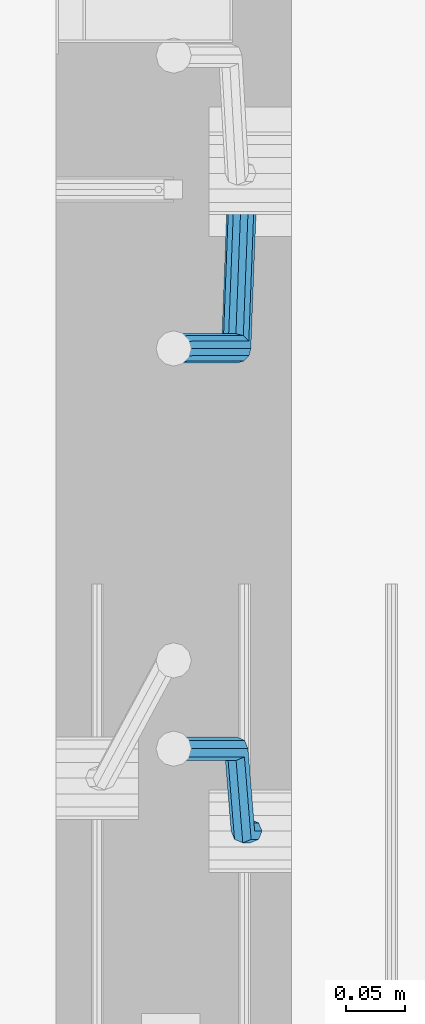
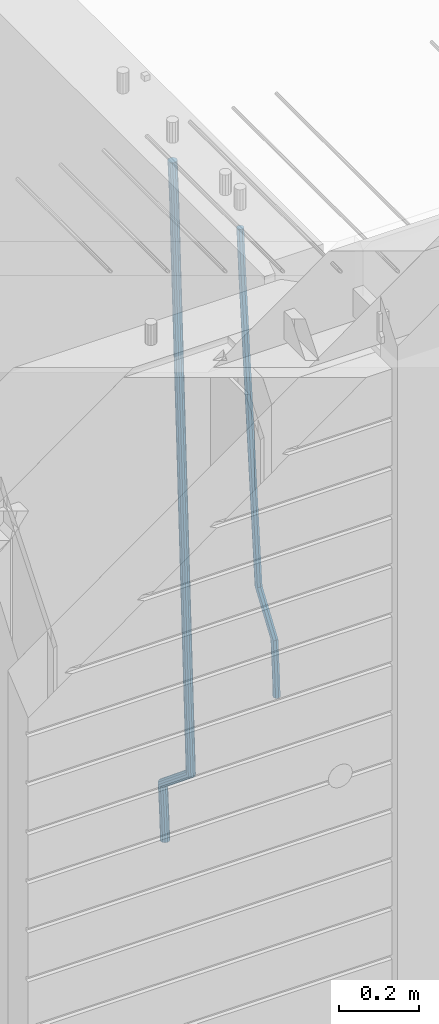
# One storey, part 104 of 341: 2 beams, 1 element without a shape of its own.
"""IFC2X3 building model written with IfcOpenShell, lengths in millimetres."""

from ifc_helpers import new_model, si_unit, frame, origin_with_axes, place, context, subcontext, project, spatial, faceted_brep, material, type_object, element, aggregate, save


model = new_model("IFC2X3")

# Units and contexts
model_context = context("Model", 3, precision=1e-05, world=origin_with_axes())
body_context = subcontext(model_context, "Body", "Model", "MODEL_VIEW")
ifc_project = project(units=[si_unit("LENGTHUNIT", "METRE", prefix="MILLI"), si_unit("AREAUNIT", "SQUARE_METRE"), si_unit("VOLUMEUNIT", "CUBIC_METRE"), si_unit("MASSUNIT", "GRAM", prefix="KILO"), si_unit("TIMEUNIT", "SECOND"), si_unit("PLANEANGLEUNIT", "RADIAN"), si_unit("SOLIDANGLEUNIT", "STERADIAN"), si_unit("THERMODYNAMICTEMPERATUREUNIT", "DEGREE_CELSIUS"), si_unit("LUMINOUSINTENSITYUNIT", "LUMEN")], contexts=[model_context])

# Site, building, storey
site_placement = place(None, origin_with_axes())
site = spatial("IfcSite", under=ifc_project, at=site_placement, CompositionType="ELEMENT")
building_placement = place(site_placement, origin_with_axes())
building = spatial("IfcBuilding", under=site, at=building_placement, CompositionType="ELEMENT")
storey_placement = place(building_placement, origin_with_axes())
storey = spatial("IfcBuildingStorey", under=building, at=storey_placement, Name="5", CompositionType="ELEMENT", Elevation=0.0)

# Assembly, beams
assembly_placement = place(storey_placement, origin_with_axes())
assembly = element("IfcElementAssembly", 1, at=assembly_placement, inside=storey, AssemblyPlace="NOTDEFINED", PredefinedType="REINFORCEMENT_UNIT")
ifc_material = material()
beam_type_1 = type_object("IfcBeamType", Name="D20", PredefinedType="NOTDEFINED")
beam_1_placement = place(assembly_placement, frame((28675.0000022791, 8255.00000000393, 94990.0), z_axis=(-0.999642804636942, -0.000205726999925762, -0.0267249099902983), x_axis=(-0.0267249099948371, 4.30000201934385e-08, 0.999642825806181)))
beam_1 = element("IfcBeam", 2, at=beam_1_placement, type_object=beam_type_1, material=ifc_material, Name="JM20", ObjectType="D20", context=body_context, shape_type="Brep", body=[
    faceted_brep([(0.0, -10.0, 0.0), (-4.19531716033816e-08, -7.07106781186667, -7.07106781187031), (60.4266690400545, -7.0710677960451, -7.07106780570757), (60.4266690441291, -9.99999998418934, 6.15546014159918e-09), (0.0, 0.0, -10.0), (60.426669036824, 1.58106558956206e-08, -9.99999999384454), (4.196772351861e-08, 7.07106781186303, -7.07106781186667), (60.4266690363438, 7.07106782768096, -7.07106780570757), (0.0, 10.0, 0.0), (60.4266690388904, 10.0000000158179, 6.15182216279209e-09), (4.196772351861e-08, 7.07106781185939, 7.07106781185939), (60.4266690429649, 7.07106782768096, 7.07106781802577), (0.0, 0.0, 10.0), (60.4266690461809, 1.58179318532348e-08, 10.0000000061555), (-4.19531716033816e-08, -7.07106781187031, 7.07106781185939), (60.4266690466611, -7.07106779605238, 7.07106781802213), (61.0378400410118, -7.07106779588503, -7.07106780564936), (60.991799419251, -9.99999998403655, 6.21366780251265e-09), (61.0569027789461, 1.5985278878361e-08, -9.99999999378269), (61.0378209396877, 7.07106782784831, -7.07106780564936), (60.9917724058905, 10.0000000159635, 6.21366780251265e-09), (60.9457317841297, 7.07106782781193, 7.0710678180767), (60.9266690461809, 1.59488990902901e-08, 10.0000000062028), (60.9457508854539, -7.07106779591413, 7.0710678180767), (61.6489592143771, -7.07106614513759, -7.06310863441468), (61.5568818710308, -9.9999984576425, 0.00735959856683621), (61.6870830769039, 1.71821739058942e-06, -9.99179257185824), (61.6489210170112, 7.07106947854481, -7.06310888312146), (61.556827851804, 10.0000015422847, 0.00735924683976918), (61.4647505084577, 7.07106922979438, 7.07782747982128), (61.4266266459163, 1.36643211590126e-06, 10.0065114172685), (61.464788705809, -7.07106639389531, 7.07782772852806), (173.929884088837, -7.07076285404219, -5.60077011527756), (173.837806745476, -9.99969516654164, 1.46969811770396), (173.968007951422, 0.000305009316434735, -8.52945405272476), (173.929845891558, 7.07137276964022, -5.6007703639807), (173.837752726366, 10.0003048333874, 1.46969776598417), (173.745675383005, 7.07137252088796, 8.54016599896204), (173.70755152042, 0.000304657529341057, 11.4688499364056), (173.745713580298, -7.07076310279444, 8.54016624766882), (178.967651291154, -7.07074924610424, -5.53515860522748), (179.629472357934, -9.99967952218321, 1.54512834527122), (177.143594814726, 0.000313587164782803, -8.48809544264077), (175.225810474018, 7.07137627027805, -5.58389181644088), (174.337710326101, 10.0003061838652, 1.47620917704262), (174.999531392881, 7.07137590778439, 8.5564961275486), (176.823587869323, 0.000313074517180212, 11.5094329649655), (178.741372210017, -7.07074960859609, 8.60522933875836), (183.345669120055, -4.57893716864601, -5.45009559540631), (184.66265755528, -7.13496947462954, 1.64292097623184), (179.903304691441, 1.57104232098936, -8.43447546265816), (176.352054665098, 7.71239441757098, -5.56200937456015), (174.772193143071, 10.2475983542226, 1.48465099193709), (176.089181578311, 7.69156604824093, 8.57766756357887), (179.531546006911, 1.54158655860192, 11.5620474308307), (183.082796033268, -4.59976553797787, 8.68958134273271), (300.866238429953, 62.309592161384, -3.16672130776351), (302.183226865163, 59.7535598554005, 3.92629526388191), (297.423874001339, 68.4595716510194, -6.15110117501899), (293.872623974981, 74.6009237475992, -3.27863508691371), (292.292762452984, 77.1361276842526, 3.7680252795908), (293.609750888194, 74.5800953782691, 10.8610418512253), (297.052115316808, 68.4301158886319, 13.8454217184808), (300.603365343151, 62.2887637920539, 10.9729556303828), (301.984297885341, 62.9459518481417, -3.14499789178808), (302.617709682163, 60.0008520257597, 3.93473707877274), (300.171977137725, 70.023694240961, -6.09770670902071), (298.242380353928, 77.0880337014878, -3.19373259352506), (297.325839159952, 80.0007759829532, 3.86581580262282), (297.959250956774, 77.0556761605694, 10.9455507731909), (299.771571704376, 69.9779337677501, 13.8982595904236), (301.701168488187, 62.9135943072251, 10.9942854749243), (303.270651347979, 62.9459576083173, -3.11711828318948), (303.117592289826, 60.0008542641881, 3.94557121718026), (303.333733847743, 70.0237083990232, -6.02918080060772), (303.269886916285, 77.0880562142083, -3.08476960685584), (303.116511220142, 80.0008019130601, 3.99131915397084), (302.963452161959, 77.0556985689309, 11.0540086543406), (302.900369662209, 69.9779477782249, 13.9660711717588), (302.964216593668, 62.9135999630416, 11.0216599780069), (1294.7217320068, 62.9503972368293, 18.3709632433638), (1294.56867294862, 60.005293892702, 25.4336527437299), (1294.78481450655, 70.0281480275353, 15.4589007259456), (1294.72096757509, 77.0924958427204, 18.4033119196974), (1294.56759187893, 80.0052415415721, 25.4794006805241), (1294.41453282078, 77.0601381974448, 32.5420901808939), (1294.35145032103, 69.9823874067388, 35.4541526983121), (1294.41529725248, 62.9180395915519, 32.5097415045602), (1295.22161461448, 62.9503994752577, 18.3817973817677), (1295.07888017438, 60.0052961773617, 25.4447106513508), (1295.31867057628, 70.028150418093, 15.4704711836021), (1295.31319399366, 77.0924984946578, 18.4161474592547), (1295.20839297447, 80.0052444110206, 25.4932889968004), (1295.06565853437, 77.0601411131283, 32.5562022663908), (1294.96860257258, 69.9823901702894, 35.4675284645564), (1294.97407915516, 62.9180420937282, 32.5218521889037), (1295.72152784184, 62.94388042639, 18.3884507330331), (1295.58911865226, 59.9986424835042, 25.4515014215031), (1295.85255934671, 70.0211883158863, 15.477576715788), (1295.90545668837, 77.0847751754136, 18.4240298907134), (1295.84923332153, 79.9968876216644, 25.5018179488325), (1295.71682413192, 77.0516496787768, 32.5648686373061), (1295.58579262707, 69.9743417892805, 35.4757426545511), (1295.53289528542, 62.9107549297532, 32.5292894796257), (1317.55234549895, 62.6591986870044, 18.6789973526284), (1317.41993630935, 59.7139607441186, 25.742048041102), (1317.68337700378, 69.7365065765007, 15.7681233353796), (1317.73627434546, 76.8000934360261, 18.7145765103051), (1317.68005097858, 79.7122058822752, 25.7923645684241), (1317.54764178899, 76.7669679393894, 32.8554152568977), (1317.41661028414, 69.6896600498949, 35.7662892741391), (1317.36371294248, 62.6260731903676, 32.8198360992174), (1318.18764454535, 62.6509141582064, 18.6874525554158), (1318.08001896468, 59.7053530281173, 25.7508330892488), (1318.26149780396, 69.7289676726632, 15.7758175521922), (1318.25831650323, 76.7932858179247, 18.7215243757819), (1318.17996420598, 79.7056868334112, 25.7990179196931), (1318.07233862529, 76.7601257033202, 32.8623984535188), (1317.9984853667, 69.6820721888635, 35.7740334567425), (1318.00166666745, 62.617754043602, 32.82832663316), (1318.82299738188, 62.6527874709518, 18.695714940186), (1318.74015733854, 59.7073214972279, 25.7594258266035), (1318.83966783619, 69.7306617061313, 15.783316930032), (1318.78040337538, 76.7948214685675, 18.7282750514532), (1318.67992031686, 79.7071777761994, 25.8054727775416), (1318.59708027351, 76.7617118024755, 32.8691836639591), (1318.58040981922, 69.683837567296, 35.7815816741204), (1318.63967428004, 62.6196778048579, 32.8366235526955), (1418.84378630333, 62.9510503382135, 19.9930854252816), (1418.76094625996, 60.0055843644896, 27.0567963116991), (1418.86045675761, 70.0289245733893, 17.080687415124), (1418.8011922968, 77.0930843358292, 20.0256455365488), (1418.70070923828, 80.0054406434592, 27.1028432626408), (1418.61786919495, 77.0599746697353, 34.1665541490511), (1418.60119874065, 69.9821004345595, 37.078952159216), (1418.66046320145, 62.9179406721196, 34.1339940377911)], [[[0, 1, 2, 3]], [[1, 4, 5, 2]], [[4, 6, 7, 5]], [[6, 8, 9, 7]], [[8, 10, 11, 9]], [[10, 12, 13, 11]], [[12, 14, 15, 13]], [[14, 0, 3, 15]], [[14, 12, 10, 8, 6, 4, 1, 0]], [[3, 2, 16, 17]], [[2, 5, 18, 16]], [[5, 7, 19, 18]], [[7, 9, 20, 19]], [[9, 11, 21, 20]], [[11, 13, 22, 21]], [[13, 15, 23, 22]], [[15, 3, 17, 23]], [[17, 16, 24, 25]], [[16, 18, 26, 24]], [[18, 19, 27, 26]], [[19, 20, 28, 27]], [[20, 21, 29, 28]], [[21, 22, 30, 29]], [[22, 23, 31, 30]], [[23, 17, 25, 31]], [[25, 24, 32, 33]], [[24, 26, 34, 32]], [[26, 27, 35, 34]], [[27, 28, 36, 35]], [[28, 29, 37, 36]], [[29, 30, 38, 37]], [[30, 31, 39, 38]], [[31, 25, 33, 39]], [[33, 32, 40, 41]], [[32, 34, 42, 40]], [[34, 35, 43, 42]], [[35, 36, 44, 43]], [[36, 37, 45, 44]], [[37, 38, 46, 45]], [[38, 39, 47, 46]], [[39, 33, 41, 47]], [[41, 40, 48, 49]], [[40, 42, 50, 48]], [[42, 43, 51, 50]], [[43, 44, 52, 51]], [[44, 45, 53, 52]], [[45, 46, 54, 53]], [[46, 47, 55, 54]], [[47, 41, 49, 55]], [[49, 48, 56, 57]], [[48, 50, 58, 56]], [[50, 51, 59, 58]], [[51, 52, 60, 59]], [[52, 53, 61, 60]], [[53, 54, 62, 61]], [[54, 55, 63, 62]], [[55, 49, 57, 63]], [[57, 56, 64, 65]], [[56, 58, 66, 64]], [[58, 59, 67, 66]], [[59, 60, 68, 67]], [[60, 61, 69, 68]], [[61, 62, 70, 69]], [[62, 63, 71, 70]], [[63, 57, 65, 71]], [[65, 64, 72, 73]], [[64, 66, 74, 72]], [[66, 67, 75, 74]], [[67, 68, 76, 75]], [[68, 69, 77, 76]], [[69, 70, 78, 77]], [[70, 71, 79, 78]], [[71, 65, 73, 79]], [[73, 72, 80, 81]], [[72, 74, 82, 80]], [[74, 75, 83, 82]], [[75, 76, 84, 83]], [[76, 77, 85, 84]], [[77, 78, 86, 85]], [[78, 79, 87, 86]], [[79, 73, 81, 87]], [[81, 80, 88, 89]], [[80, 82, 90, 88]], [[82, 83, 91, 90]], [[83, 84, 92, 91]], [[84, 85, 93, 92]], [[85, 86, 94, 93]], [[86, 87, 95, 94]], [[87, 81, 89, 95]], [[89, 88, 96, 97]], [[88, 90, 98, 96]], [[90, 91, 99, 98]], [[91, 92, 100, 99]], [[92, 93, 101, 100]], [[93, 94, 102, 101]], [[94, 95, 103, 102]], [[95, 89, 97, 103]], [[97, 96, 104, 105]], [[96, 98, 106, 104]], [[98, 99, 107, 106]], [[99, 100, 108, 107]], [[100, 101, 109, 108]], [[101, 102, 110, 109]], [[102, 103, 111, 110]], [[103, 97, 105, 111]], [[105, 104, 112, 113]], [[104, 106, 114, 112]], [[106, 107, 115, 114]], [[107, 108, 116, 115]], [[108, 109, 117, 116]], [[109, 110, 118, 117]], [[110, 111, 119, 118]], [[111, 105, 113, 119]], [[113, 112, 120, 121]], [[112, 114, 122, 120]], [[114, 115, 123, 122]], [[115, 116, 124, 123]], [[116, 117, 125, 124]], [[117, 118, 126, 125]], [[118, 119, 127, 126]], [[119, 113, 121, 127]], [[121, 120, 128, 129]], [[120, 122, 130, 128]], [[122, 123, 131, 130]], [[123, 124, 132, 131]], [[124, 125, 133, 132]], [[125, 126, 134, 133]], [[126, 127, 135, 134]], [[127, 121, 129, 135]], [[130, 131, 132, 133, 134, 135, 129, 128]]]),
])
beam_type_2 = type_object("IfcBeamType", Name="D25", PredefinedType="NOTDEFINED")
beam_2_placement = place(assembly_placement, frame((28675.0000022791, 8815.00000000393, 94210.0), z_axis=(-0.999642804636942, -0.000205726999925762, -0.0267249099902983), x_axis=(-0.0267249099948371, 4.30000201934385e-08, 0.999642825806181)))
beam_2 = element("IfcBeam", 3, at=beam_2_placement, type_object=beam_type_2, material=ifc_material, Name="JM25", ObjectType="D25", context=body_context, shape_type="Brep", body=[
    faceted_brep([(-7.41420080885291e-08, -12.5, -3.63797880709171e-12), (-6.42030499875546e-08, -10.8253175473074, -6.25000000000364), (60.4103898235917, -10.8253175318459, -6.2499999938409), (60.4103898269532, -12.4999999845422, 6.16273609921336e-09), (-3.70782800018787e-08, -6.25000000000364, -10.8253175473074), (60.4103898202884, -6.24999998454587, -10.8253175411446), (-1.45519152283669e-11, -3.63797880709171e-12, -12.5), (60.4103898179019, 1.54577719513327e-08, -12.4999999938373), (3.70637280866504e-08, 6.25, -10.8253175473074), (60.410389817087, 6.25000001545777, -10.825317541141), (6.42030499875546e-08, 10.8253175473001, -6.25000000000364), (60.410389818062, 10.8253175627578, -6.24999999383726), (7.41420080885291e-08, 12.4999999999927, 0.0), (60.4103898205503, 12.5000000154541, 6.16273609921336e-09), (6.42176019027829e-08, 10.8253175473001, 6.24999999999636), (60.4103898238973, 10.8253175627651, 6.2500000061591), (3.70928319171071e-08, 6.24999999999636, 10.8253175473037), (60.4103898272151, 6.25000001546141, 10.8253175534664), (1.45519152283669e-11, -3.63797880709171e-12, 12.4999999999964), (60.4103898296162, 1.54541339725256e-08, 12.5000000061591), (-3.7049176171422e-08, -6.25000000000364, 10.8253175473001), (60.4103898304165, -6.24999998454587, 10.8253175534701), (-6.41884980723262e-08, -10.8253175473074, 6.25), (60.4103898294561, -10.8253175318459, 6.25000000616637), (61.0324985728803, -10.8253175316895, -6.24999999377542), (60.991802792938, -12.4999999843931, 6.22458173893392e-09), (61.0622854283865, -6.24999998437852, -10.8253175410755), (61.0731819955545, 1.5628756955266e-08, -12.4999999937718), (61.0622685480339, 6.25000001562512, -10.8253175410791), (61.032469335245, 10.8253175629216, -6.24999999377178), (60.9917690322181, 12.5000000156033, 6.22458173893392e-09), (60.9510732522613, 10.8253175629034, 6.25000000621731), (60.9212863967696, 6.25000001558874, 10.8253175535247), (60.9103898296162, 1.55814632307738e-08, 12.5000000062137), (60.9213032771368, -6.24999998441126, 10.8253175535174), (60.9511024898966, -10.8253175317113, 6.25000000621731), (61.6545545670233, -10.8253158516927, -6.24189838219536), (61.573166454793, -12.499998414296, 0.00757164385504439), (61.7141257553885, -6.24999822394238, -10.8168280205282), (61.7359179680789, 1.80548886419274e-06, -12.491368569139), (61.7140919992817, 6.25000177601396, -10.8168282403167), (61.6544960997562, 10.8253192428383, -6.2418987628771), (61.5730989426083, 12.5000015856094, 0.0075712042817031), (61.4917108303925, 10.8253190230062, 6.25704123032847), (61.4321396420273, 6.25000139525582, 10.8319708686649), (61.4103474293224, 1.36582457344048e-06, 12.5065114172721), (61.4321733981196, -6.24999860470052, 10.8319710884571), (61.4917692976451, -10.8253160715249, 6.25704161101385), (170.650707434237, -10.8250214850323, -4.82234049238832), (170.569319321992, -12.4997040476355, 1.42712953365844), (170.710278622631, -6.24970385728193, -9.39727013072479), (170.732070835351, 0.000296172149319318, -11.071810679332), (170.710244866626, 6.2502961426726, -9.39727035051328), (170.650648967101, 10.8256136094988, -4.8223408730737), (170.569251809982, 12.5002959522735, 1.42712909408874), (170.487863697752, 10.8256133896703, 7.67659912013187), (170.428292509343, 6.2502957619181, 12.2515287584683), (170.406500296609, 0.000295732492304523, 13.9260693070792), (170.428326265363, -6.24970423803461, 12.2515289782568), (170.487922164859, -10.825021704859, 7.67659950081725), (171.95945989441, -10.8250179504703, -4.80529539646886), (171.069276921742, -12.4997026973942, 1.43364094472054), (174.195854831123, -6.24969444374983, -9.35187424218384), (177.179221514642, 0.00031358403248305, -10.9878434623934), (180.110169251391, 6.25032152914355, -9.2748464256947), (182.203352962257, 10.8256448100037, -4.67187930471846), (182.897905762278, 12.5003292483925, 1.58769657769517), (182.007722789611, 10.8256445014722, 7.82663291887729), (179.771327852883, 6.25032099474811, 12.3732117645959), (176.787961169364, 0.000312966967612738, 14.0091809848018), (173.857013432615, -6.24969497814527, 12.2961839481068), (171.763829721749, -10.8250182590036, 7.69321682713053), (172.789272050257, -11.8370779460765, -4.78886711087034), (171.386274143355, -12.8863205656235, 1.43991672756601), (176.405878190024, -8.94509510172611, -9.30812109317048), (181.267025868161, -4.98527650023061, -10.9069147643713), (186.070174490029, -1.01865233804529, -9.15685265142747), (189.528324261279, 1.89192364390146, -4.52686248419923), (190.714866743365, 2.96656496173455, 1.74245361104113), (189.311868836463, 1.91732234219126, 7.97123744947385), (185.695262696681, -0.974660502160987, 12.4904914317667), (180.834115018544, -4.93447910365467, 14.0892851029712), (176.030966396691, -8.90110326583999, 12.339222990031), (172.572816625441, -11.8116792477867, 7.70923282279909), (287.643682825365, -151.916436441259, -2.51502591843382), (286.240684918463, -152.965679060806, 3.71375791999526), (291.260288965132, -149.024453596909, -7.03427990073396), (296.121436643283, -145.064634995419, -8.63307357193844), (300.924585265137, -141.098010833231, -6.88301145899459), (304.382735036386, -138.187434851283, -2.25302129176634), (305.569277518473, -137.11279353345, 4.01629480347401), (304.166279611571, -138.162036152991, 10.2450786419104), (300.549673471804, -141.054018997345, 14.7643326242032), (295.688525793681, -145.013837598837, 16.3631262954077), (290.885377171784, -148.980461761024, 14.6130641824639), (287.427227400578, -151.891037742971, 9.98307401523562), (294.916872503818, -160.787003426849, -2.37103424950692), (294.057255182415, -162.498966818901, 3.86850721808514), (297.130944177028, -156.184453900582, -6.91805504216973), (300.10621148521, -149.924567668779, -8.55418461054069), (303.04545395587, -143.684676191968, -6.84102335805801), (305.16110394265, -139.136753352217, -2.23761145882963), (305.886274740114, -137.499411401677, 4.02257058631221), (305.026657418683, -139.211374793726, 10.2621120539116), (302.812585745487, -143.813924319997, 14.8091328465744), (299.83731843729, -150.073810551799, 16.445262414938), (296.89807596663, -156.313702028609, 14.732101162459), (294.782425979865, -160.861624868359, 10.1286892632306), (306.388880108789, -160.787002563869, -2.36635924463553), (306.386337397649, -162.498965891449, 3.87353149295086), (306.390733102453, -156.184453204016, -6.91428154760433), (306.391399870467, -149.924567195976, -8.55162330764142), (306.390701752913, -143.684675940322, -6.83966012240489), (306.388825809801, -139.13675325986, -2.23711114485923), (306.386274698583, -137.499411364064, 4.02277434335338), (306.383731987473, -139.21137469164, 10.2626650809325), (306.381878993809, -143.813924051496, 14.8105873839049), (306.38121222578, -150.073810059535, 16.4479291439384), (306.381910343349, -156.31370131519, 14.7359659587019), (306.38378628646, -160.86162399565, 10.1334169811526), (2074.25685482159, -160.78686957629, -1.64592811491093), (2074.25431211045, -162.49883290387, 4.59396262267182), (2074.25870781526, -156.184320216433, -6.19385041787609), (2074.25937458327, -149.924434208398, -7.83119217791682), (2074.25867646572, -143.684542952742, -6.11922899268029), (2074.25680052261, -139.136620272282, -1.51668001513099), (2074.25424941139, -137.499278376485, 4.7432054730707), (2074.25170670026, -139.211241704063, 10.9830962106571), (2074.24985370661, -143.813791063918, 15.5310185136332), (2074.24918693858, -150.073677071958, 17.1683602736666), (2074.24988505615, -156.313568327612, 15.4563970884265), (2074.25176099925, -160.861491008072, 10.8538481108772), (2074.83800415983, -160.786869532572, -1.64569128836229), (2074.78405199363, -162.498832864021, 4.59417849914462), (2074.89919820712, -156.184320168253, -6.19358940901657), (2074.95123723999, -149.924434156354, -7.83091023412271), (2074.98017744161, -143.684542898467, -6.11893497085839), (2074.9782643083, -139.136620218011, -1.51638600846127), (2074.94601046259, -137.499278324447, 4.74348737546097), (2074.89205829642, -139.211241655892, 10.9833571629642), (2074.83086424912, -143.813791020213, 15.5312552836185), (2074.77882521624, -150.073677032115, 17.1685761087319), (2074.74988501464, -156.313568289999, 15.4566008454603), (2074.75179814795, -160.861490970456, 10.8540518830705), (2075.41905269311, -160.794446422529, -1.63795810662486), (2075.31369998924, -162.505739489452, 4.60122759051956), (2075.53957750089, -156.192670733069, -6.18506659349441), (2075.64297988769, -149.933454500813, -7.82170382312688), (2075.70155326747, -143.693949660443, -6.10933417154229), (2075.69960295041, -139.146026495109, -1.50678570403034), (2075.6376515224, -137.508297344199, 4.75269243442381), (2075.53229881854, -139.219590411121, 10.9918781315719), (2075.41177401076, -143.821366100581, 15.5389866184414), (2075.30837162396, -150.080582332837, 17.1756238480739), (2075.24979824419, -156.320087173208, 15.4632541964893), (2075.25174856123, -160.868010338543, 10.8607057289737), (2097.19475506655, -161.07840222163, -1.34814502872177), (2097.0894023627, -162.789695288553, 4.89104066842629), (2097.31527987434, -156.47662653217, -5.89525351558768), (2097.41868226114, -150.217410299914, -7.53189074522379), (2097.47725564092, -143.977905459546, -5.8195210936392), (2097.47530532385, -139.42998229421, -1.21697262612361), (2097.41335389586, -137.7922531433, 5.0425055123269), (2097.308001192, -139.503546210224, 11.2816912094786), (2097.18747638421, -144.105321899684, 15.8287996963445), (2097.08407399742, -150.36453813194, 17.465436925977), (2097.02550061764, -156.604042972309, 15.7530672743924), (2097.02745093469, -161.151966137644, 11.1505188068804), (2097.88009758113, -161.08733910817, -1.33902379716892), (2097.78950535266, -162.798824652125, 4.90035834732043), (2097.96299662867, -156.48507277769, -5.88663304572037), (2098.01598976244, -150.225199207291, -7.52394117269068), (2098.02487751505, -143.985046464883, -5.81223278769903), (2097.98727842035, -139.436658438441, -1.21015877018363), (2097.9132671254, -137.79877202651, 5.04915886335584), (2097.82267489695, -139.510257570466, 11.2885410078416), (2097.73977584939, -144.112523900945, 15.8361502563967), (2097.68678271561, -150.372397471347, 17.4734583833706), (2097.67789496301, -156.612550213753, 15.7617499983789), (2097.7154940577, -161.160938240195, 11.1596759808635), (2098.56549792843, -161.085317088931, -1.33009606953055), (2098.4896672887, -162.796737016384, 4.9094834726202), (2098.61076827119, -156.483178710125, -5.87820933279363), (2098.61334816522, -150.223461142012, -7.51619304119231), (2098.57254632999, -143.98345065182, -5.80515078284952), (2098.49929558429, -139.435153011162, -1.20355494909745), (2098.4132234063, -137.797280899784, 5.05560057250841), (2098.33739276657, -139.508700827235, 11.2951801146628), (2098.29212242381, -144.110839206043, 15.8432933779259), (2098.28954252979, -150.370556774154, 17.4812770863246), (2098.33034436501, -156.610567264344, 15.7702348279781), (2098.40359511071, -161.158864905006, 11.1686389942297), (2198.56627518767, -160.787113942532, -0.0329775665668421), (2198.49044454792, -162.498533869981, 6.20660197558027), (2198.61154553041, -156.184975563721, -4.58109082982992), (2198.61412542444, -149.92525799561, -6.21907453823587), (2198.57332358921, -143.68524750542, -4.50803227988581), (2198.50007284353, -139.136949864758, 0.0935635538662609), (2198.41400066552, -137.499077753379, 6.35271907547576), (2198.33817002579, -139.210497680831, 12.5922986176229), (2198.29289968305, -143.81263605964, 17.1404118808859), (2198.29031978901, -150.072353627755, 18.7783955892846), (2198.33112162424, -156.312364117945, 17.0673533309418), (2198.40437236994, -160.860661758603, 12.4657574971934)], [[[0, 1, 2, 3]], [[1, 4, 5, 2]], [[4, 6, 7, 5]], [[6, 8, 9, 7]], [[8, 10, 11, 9]], [[10, 12, 13, 11]], [[12, 14, 15, 13]], [[14, 16, 17, 15]], [[16, 18, 19, 17]], [[18, 20, 21, 19]], [[20, 22, 23, 21]], [[22, 0, 3, 23]], [[22, 20, 18, 16, 14, 12, 10, 8, 6, 4, 1, 0]], [[3, 2, 24, 25]], [[2, 5, 26, 24]], [[5, 7, 27, 26]], [[7, 9, 28, 27]], [[9, 11, 29, 28]], [[11, 13, 30, 29]], [[13, 15, 31, 30]], [[15, 17, 32, 31]], [[17, 19, 33, 32]], [[19, 21, 34, 33]], [[21, 23, 35, 34]], [[23, 3, 25, 35]], [[25, 24, 36, 37]], [[24, 26, 38, 36]], [[26, 27, 39, 38]], [[27, 28, 40, 39]], [[28, 29, 41, 40]], [[29, 30, 42, 41]], [[30, 31, 43, 42]], [[31, 32, 44, 43]], [[32, 33, 45, 44]], [[33, 34, 46, 45]], [[34, 35, 47, 46]], [[35, 25, 37, 47]], [[37, 36, 48, 49]], [[36, 38, 50, 48]], [[38, 39, 51, 50]], [[39, 40, 52, 51]], [[40, 41, 53, 52]], [[41, 42, 54, 53]], [[42, 43, 55, 54]], [[43, 44, 56, 55]], [[44, 45, 57, 56]], [[45, 46, 58, 57]], [[46, 47, 59, 58]], [[47, 37, 49, 59]], [[49, 48, 60, 61]], [[48, 50, 62, 60]], [[50, 51, 63, 62]], [[51, 52, 64, 63]], [[52, 53, 65, 64]], [[53, 54, 66, 65]], [[54, 55, 67, 66]], [[55, 56, 68, 67]], [[56, 57, 69, 68]], [[57, 58, 70, 69]], [[58, 59, 71, 70]], [[59, 49, 61, 71]], [[61, 60, 72, 73]], [[60, 62, 74, 72]], [[62, 63, 75, 74]], [[63, 64, 76, 75]], [[64, 65, 77, 76]], [[65, 66, 78, 77]], [[66, 67, 79, 78]], [[67, 68, 80, 79]], [[68, 69, 81, 80]], [[69, 70, 82, 81]], [[70, 71, 83, 82]], [[71, 61, 73, 83]], [[73, 72, 84, 85]], [[72, 74, 86, 84]], [[74, 75, 87, 86]], [[75, 76, 88, 87]], [[76, 77, 89, 88]], [[77, 78, 90, 89]], [[78, 79, 91, 90]], [[79, 80, 92, 91]], [[80, 81, 93, 92]], [[81, 82, 94, 93]], [[82, 83, 95, 94]], [[83, 73, 85, 95]], [[85, 84, 96, 97]], [[84, 86, 98, 96]], [[86, 87, 99, 98]], [[87, 88, 100, 99]], [[88, 89, 101, 100]], [[89, 90, 102, 101]], [[90, 91, 103, 102]], [[91, 92, 104, 103]], [[92, 93, 105, 104]], [[93, 94, 106, 105]], [[94, 95, 107, 106]], [[95, 85, 97, 107]], [[97, 96, 108, 109]], [[96, 98, 110, 108]], [[98, 99, 111, 110]], [[99, 100, 112, 111]], [[100, 101, 113, 112]], [[101, 102, 114, 113]], [[102, 103, 115, 114]], [[103, 104, 116, 115]], [[104, 105, 117, 116]], [[105, 106, 118, 117]], [[106, 107, 119, 118]], [[107, 97, 109, 119]], [[109, 108, 120, 121]], [[108, 110, 122, 120]], [[110, 111, 123, 122]], [[111, 112, 124, 123]], [[112, 113, 125, 124]], [[113, 114, 126, 125]], [[114, 115, 127, 126]], [[115, 116, 128, 127]], [[116, 117, 129, 128]], [[117, 118, 130, 129]], [[118, 119, 131, 130]], [[119, 109, 121, 131]], [[121, 120, 132, 133]], [[120, 122, 134, 132]], [[122, 123, 135, 134]], [[123, 124, 136, 135]], [[124, 125, 137, 136]], [[125, 126, 138, 137]], [[126, 127, 139, 138]], [[127, 128, 140, 139]], [[128, 129, 141, 140]], [[129, 130, 142, 141]], [[130, 131, 143, 142]], [[131, 121, 133, 143]], [[133, 132, 144, 145]], [[132, 134, 146, 144]], [[134, 135, 147, 146]], [[135, 136, 148, 147]], [[136, 137, 149, 148]], [[137, 138, 150, 149]], [[138, 139, 151, 150]], [[139, 140, 152, 151]], [[140, 141, 153, 152]], [[141, 142, 154, 153]], [[142, 143, 155, 154]], [[143, 133, 145, 155]], [[145, 144, 156, 157]], [[144, 146, 158, 156]], [[146, 147, 159, 158]], [[147, 148, 160, 159]], [[148, 149, 161, 160]], [[149, 150, 162, 161]], [[150, 151, 163, 162]], [[151, 152, 164, 163]], [[152, 153, 165, 164]], [[153, 154, 166, 165]], [[154, 155, 167, 166]], [[155, 145, 157, 167]], [[157, 156, 168, 169]], [[156, 158, 170, 168]], [[158, 159, 171, 170]], [[159, 160, 172, 171]], [[160, 161, 173, 172]], [[161, 162, 174, 173]], [[162, 163, 175, 174]], [[163, 164, 176, 175]], [[164, 165, 177, 176]], [[165, 166, 178, 177]], [[166, 167, 179, 178]], [[167, 157, 169, 179]], [[169, 168, 180, 181]], [[168, 170, 182, 180]], [[170, 171, 183, 182]], [[171, 172, 184, 183]], [[172, 173, 185, 184]], [[173, 174, 186, 185]], [[174, 175, 187, 186]], [[175, 176, 188, 187]], [[176, 177, 189, 188]], [[177, 178, 190, 189]], [[178, 179, 191, 190]], [[179, 169, 181, 191]], [[181, 180, 192, 193]], [[180, 182, 194, 192]], [[182, 183, 195, 194]], [[183, 184, 196, 195]], [[184, 185, 197, 196]], [[185, 186, 198, 197]], [[186, 187, 199, 198]], [[187, 188, 200, 199]], [[188, 189, 201, 200]], [[189, 190, 202, 201]], [[190, 191, 203, 202]], [[191, 181, 193, 203]], [[194, 195, 196, 197, 198, 199, 200, 201, 202, 203, 193, 192]]]),
])
aggregate(assembly, [beam_1, beam_2])

save(model, "model.ifc")
